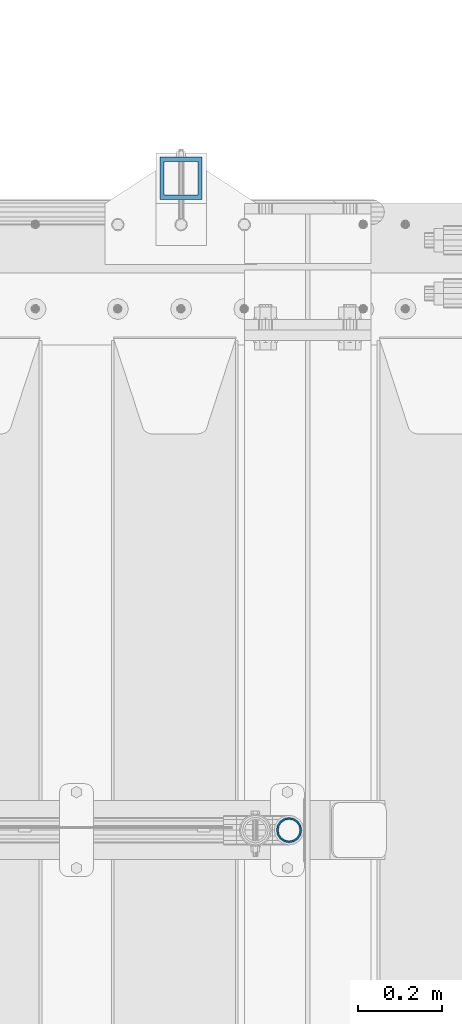
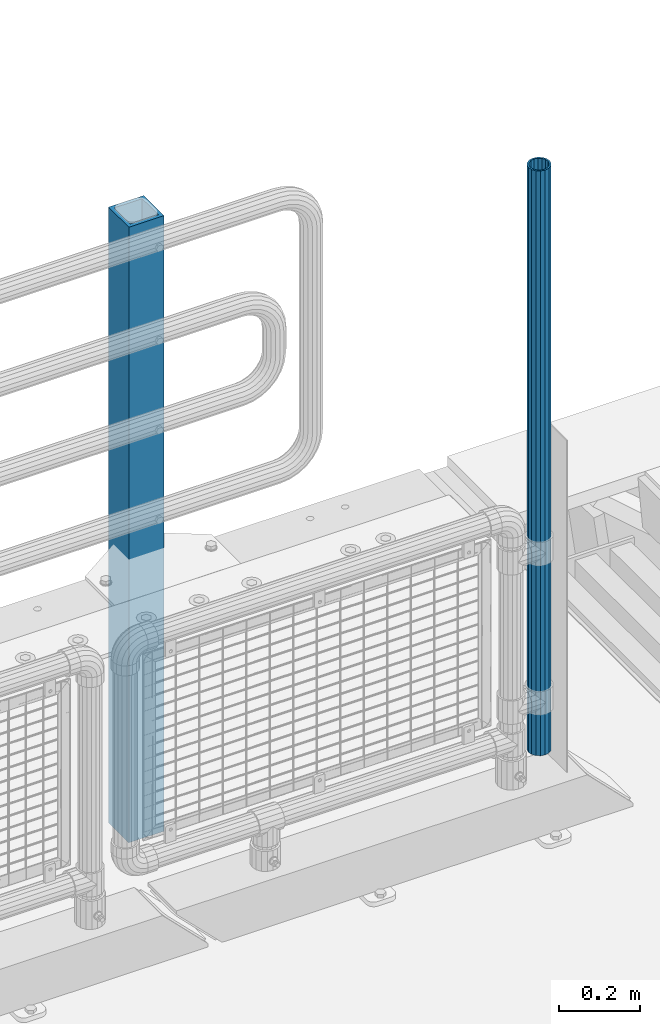
# One storey, part 52 of 208: 2 columns.
"""IFC2X3 building model written with IfcOpenShell, lengths in millimetres."""

from ifc_helpers import new_model, si_unit, frame, origin_with_axes, place, context, subcontext, project, spatial, faceted_brep, material, type_object, element, save


model = new_model("IFC2X3")

# Units and contexts
model_context = context("Model", 3, precision=1e-05, world=origin_with_axes())
body_context = subcontext(model_context, "Body", "Model", "MODEL_VIEW")
ifc_project = project(units=[si_unit("LENGTHUNIT", "METRE", prefix="MILLI"), si_unit("AREAUNIT", "SQUARE_METRE"), si_unit("VOLUMEUNIT", "CUBIC_METRE"), si_unit("MASSUNIT", "GRAM", prefix="KILO"), si_unit("TIMEUNIT", "SECOND"), si_unit("PLANEANGLEUNIT", "RADIAN"), si_unit("SOLIDANGLEUNIT", "STERADIAN"), si_unit("THERMODYNAMICTEMPERATUREUNIT", "DEGREE_CELSIUS"), si_unit("LUMINOUSINTENSITYUNIT", "LUMEN")], contexts=[model_context])

# Site, building, storey
site_placement = place(None, origin_with_axes())
site = spatial("IfcSite", under=ifc_project, at=site_placement, CompositionType="ELEMENT")
building_placement = place(site_placement, origin_with_axes())
building = spatial("IfcBuilding", under=site, at=building_placement, Name="Standard", CompositionType="ELEMENT")
storey_placement = place(building_placement, origin_with_axes())
storey = spatial("IfcBuildingStorey", under=building, at=storey_placement, Name="Undefined", CompositionType="ELEMENT", Elevation=0.0)

# Columns
ifc_material_1 = material(Name="Misc_Undefined")
column_type_1 = type_object("IfcColumnType", PredefinedType="NOTDEFINED")
column_1_placement = place(storey_placement, frame((-26149.0, 4664.5, 238.02), z_axis=(-1.0, 0.0, 0.0), x_axis=(0.0, 0.0, 1.0)))
element("IfcColumn", 1, at=column_1_placement, inside=storey, type_object=column_type_1, material=ifc_material_1, context=body_context, shape_type="Brep", body=[
    faceted_brep([(0.0, -25.3500000000004, 0.0), (0.0, -23.4203461491616, 9.70102501045403), (1761.98, -23.4203461491616, 9.70102501045767), (1761.98, -25.3500000000004, 0.0), (0.0, -17.9251569030794, 17.9251569030785), (1761.98, -17.9251569030794, 17.9251569030821), (0.0, -9.70102501045494, 23.4203461491597), (1761.98, -9.70102501045494, 23.4203461491634), (0.0, 0.0, 25.3499999999985), (1761.98, 0.0, 25.3499999999985), (0.0, 9.70102501045494, 23.4203461491597), (1761.98, 9.70102501045494, 23.4203461491634), (0.0, 17.9251569030794, 17.9251569030785), (1761.98, 17.9251569030794, 17.9251569030821), (0.0, 23.4203461491616, 9.70102501045403), (1761.98, 23.4203461491616, 9.70102501045767), (0.0, 25.3500000000004, 0.0), (1761.98, 25.3500000000004, 0.0), (0.0, 23.4203461491616, -9.70102501045403), (1761.98, 23.4203461491616, -9.70102501045767), (0.0, 17.9251569030794, -17.9251569030785), (1761.98, 17.9251569030794, -17.9251569030821), (0.0, 9.70102501045494, -23.4203461491597), (1761.98, 9.70102501045494, -23.4203461491634), (0.0, 0.0, -25.3499999999985), (1761.98, 0.0, -25.3499999999985), (0.0, -9.70102501045494, -23.4203461491597), (1761.98, -9.70102501045494, -23.4203461491634), (0.0, -17.9251569030794, -17.9251569030785), (1761.98, -17.9251569030794, -17.9251569030821), (0.0, -23.4203461491616, -9.70102501045403), (1761.98, -23.4203461491616, -9.70102501045767), (0.0, -30.1499999999996, 0.0), (0.0, -27.8549679052148, -11.5379054858058), (1761.98, -27.8549679052148, -11.5379054858058), (1761.98, -30.1499999999996, 0.0), (0.0, -21.3192694527743, -21.3192694527752), (1761.98, -21.3192694527743, -21.3192694527752), (0.0, -11.5379054858076, -27.8549679052157), (1761.98, -11.5379054858076, -27.8549679052157), (0.0, 0.0, -30.1500000000015), (1761.98, 0.0, -30.1500000000015), (0.0, 11.5379054858076, -27.8549679052157), (1761.98, 11.5379054858076, -27.8549679052157), (0.0, 21.3192694527743, -21.3192694527752), (1761.98, 21.3192694527743, -21.3192694527752), (0.0, 27.8549679052157, -11.5379054858058), (1761.98, 27.8549679052157, -11.5379054858058), (0.0, 30.1499999999996, 0.0), (1761.98, 30.1499999999996, 0.0), (0.0, 27.8549679052157, 11.5379054858058), (1761.98, 27.8549679052157, 11.5379054858058), (0.0, 21.3192694527743, 21.3192694527752), (1761.98, 21.3192694527743, 21.3192694527752), (0.0, 11.5379054858076, 27.8549679052157), (1761.98, 11.5379054858076, 27.8549679052157), (0.0, 0.0, 30.1500000000015), (1761.98, 0.0, 30.1500000000015), (0.0, -11.5379054858076, 27.8549679052157), (1761.98, -11.5379054858076, 27.8549679052157), (0.0, -21.3192694527743, 21.3192694527752), (1761.98, -21.3192694527743, 21.3192694527752), (0.0, -27.8549679052157, 11.5379054858058), (1761.98, -27.8549679052157, 11.5379054858058)], [[[0, 1, 2, 3]], [[1, 4, 5, 2]], [[4, 6, 7, 5]], [[6, 8, 9, 7]], [[8, 10, 11, 9]], [[10, 12, 13, 11]], [[12, 14, 15, 13]], [[14, 16, 17, 15]], [[16, 18, 19, 17]], [[18, 20, 21, 19]], [[20, 22, 23, 21]], [[22, 24, 25, 23]], [[24, 26, 27, 25]], [[26, 28, 29, 27]], [[28, 30, 31, 29]], [[30, 0, 3, 31]], [[32, 33, 34, 35]], [[33, 36, 37, 34]], [[36, 38, 39, 37]], [[38, 40, 41, 39]], [[40, 42, 43, 41]], [[42, 44, 45, 43]], [[44, 46, 47, 45]], [[46, 48, 49, 47]], [[48, 50, 51, 49]], [[50, 52, 53, 51]], [[52, 54, 55, 53]], [[54, 56, 57, 55]], [[56, 58, 59, 57]], [[58, 60, 61, 59]], [[60, 62, 63, 61]], [[62, 32, 35, 63]], [[37, 39, 41, 43, 45, 47, 49, 51, 53, 55, 57, 59, 61, 63, 35, 34], [5, 7, 9, 11, 13, 15, 17, 19, 21, 23, 25, 27, 29, 31, 3, 2]], [[62, 60, 58, 56, 54, 52, 50, 48, 46, 44, 42, 40, 38, 36, 33, 32], [30, 28, 26, 24, 22, 20, 18, 16, 14, 12, 10, 8, 6, 4, 1, 0]]]),
])
ifc_material_2 = material()
column_type_2 = type_object("IfcColumnType", PredefinedType="NOTDEFINED")
column_2_placement = place(storey_placement, frame((-26404.9999999999, 6210.00000000021, -844.999999999998), z_axis=(0.0, -1.0, 0.0), x_axis=(0.0, 0.0, 1.0)))
element("IfcColumn", 2, at=column_2_placement, inside=storey, type_object=column_type_2, material=ifc_material_2, context=body_context, shape_type="Brep", body=[
    faceted_brep([(0.0, 40.0, -40.0), (0.0, -40.0, -40.0), (1855.0, -40.0, -40.0), (1855.0, 40.0, -40.0), (0.0, -40.0, 40.0), (1855.0, -40.0, 40.0), (0.0, 40.0, 40.0), (1855.0, 40.0, 40.0), (0.0, 50.0, -50.0), (0.0, 50.0, 50.0), (1855.0, 50.0, 50.0), (1855.0, 50.0, -50.0), (0.0, -50.0, 50.0), (1855.0, -50.0, 50.0), (0.0, -50.0, -50.0), (1855.0, -50.0, -50.0)], [[[0, 1, 2, 3]], [[1, 4, 5, 2]], [[4, 6, 7, 5]], [[6, 0, 3, 7]], [[8, 9, 10, 11]], [[9, 12, 13, 10]], [[12, 14, 15, 13]], [[14, 8, 11, 15]], [[13, 15, 11, 10], [5, 7, 3, 2]], [[14, 12, 9, 8], [6, 4, 1, 0]]]),
])

save(model, "model.ifc")
